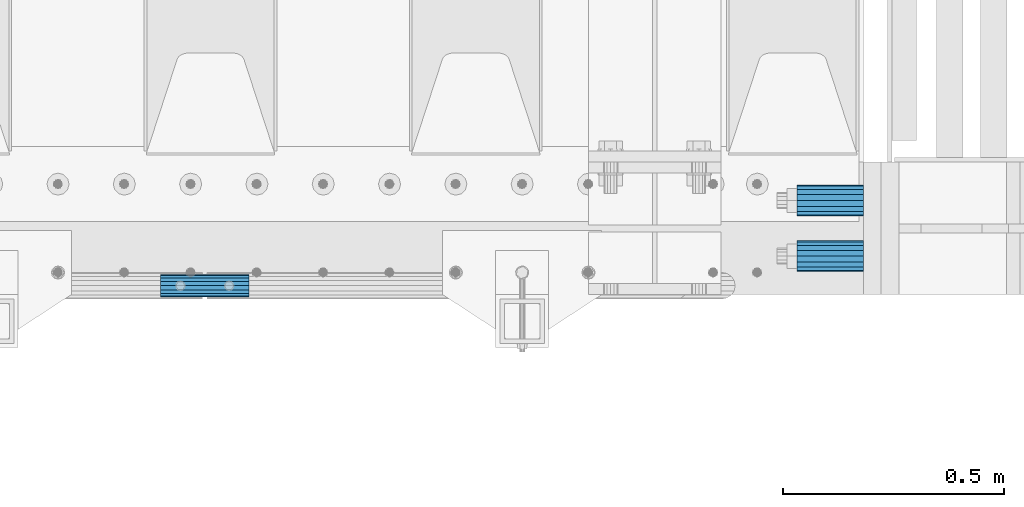
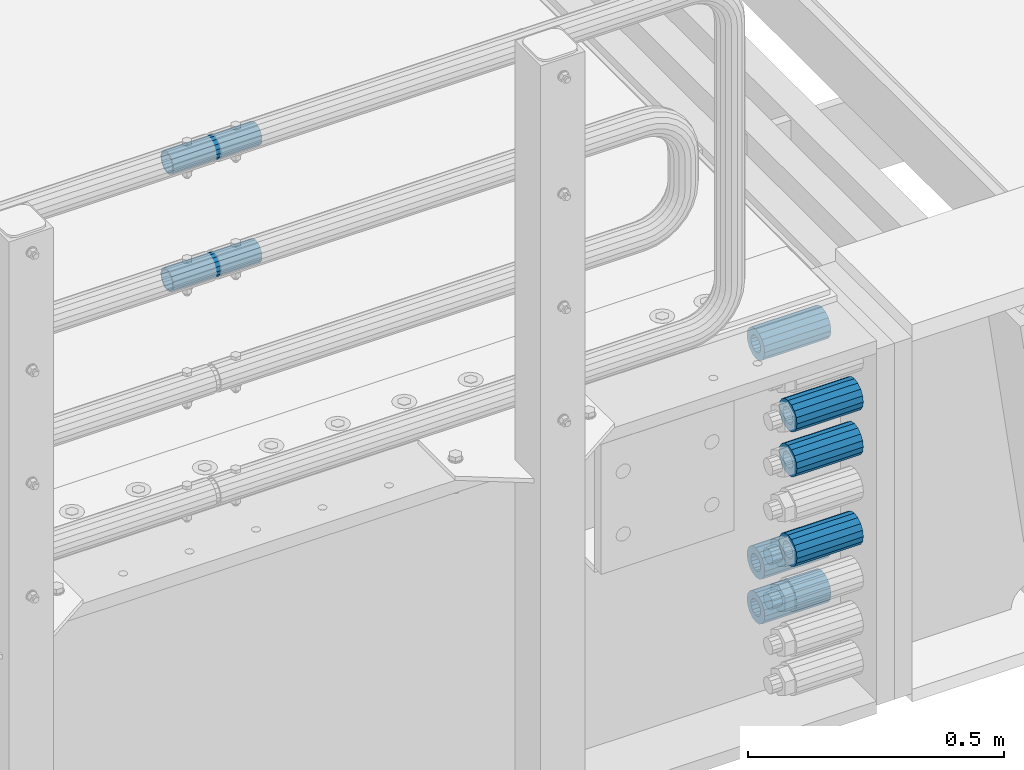
# One storey, part 137 of 240: 8 beams.
"""IFC2X3 building model written with IfcOpenShell, lengths in millimetres."""

from ifc_helpers import new_model, si_unit, frame, origin_with_axes, place, context, subcontext, project, spatial, faceted_brep, material, type_object, element, save


model = new_model("IFC2X3")

# Units and contexts
model_context = context("Model", 3, precision=1e-05, world=origin_with_axes())
body_context = subcontext(model_context, "Body", "Model", "MODEL_VIEW")
ifc_project = project(units=[si_unit("LENGTHUNIT", "METRE", prefix="MILLI"), si_unit("AREAUNIT", "SQUARE_METRE"), si_unit("VOLUMEUNIT", "CUBIC_METRE"), si_unit("MASSUNIT", "GRAM", prefix="KILO"), si_unit("TIMEUNIT", "SECOND"), si_unit("PLANEANGLEUNIT", "RADIAN"), si_unit("SOLIDANGLEUNIT", "STERADIAN"), si_unit("THERMODYNAMICTEMPERATUREUNIT", "DEGREE_CELSIUS"), si_unit("LUMINOUSINTENSITYUNIT", "LUMEN")], contexts=[model_context])

# Site, building, storey
site_placement = place(None, origin_with_axes())
site = spatial("IfcSite", under=ifc_project, at=site_placement, CompositionType="ELEMENT")
building_placement = place(site_placement, origin_with_axes())
building = spatial("IfcBuilding", under=site, at=building_placement, Name="Standard", CompositionType="ELEMENT")
storey_placement = place(building_placement, origin_with_axes())
storey = spatial("IfcBuildingStorey", under=building, at=storey_placement, Name="Undefined", CompositionType="ELEMENT", Elevation=0.0)

# Beams
ifc_material = material()
beam_type_1 = type_object("IfcBeamType", PredefinedType="NOTDEFINED")
beam_1_placement = place(storey_placement, frame((56327.0, 23937.0, -285.0), z_axis=(0.0, 0.0, 1.0), x_axis=(1.0, 0.0, 0.0)))
element("IfcBeam", 1, at=beam_1_placement, inside=storey, type_object=beam_type_1, material=ifc_material, context=body_context, shape_type="Brep", body=[
    faceted_brep([(-1.31236447487026e-07, -18.9999999995492, -6.26459950581193e-09), (0.0, -17.5537111177146, 7.27098521493673), (150.0, -17.5537111177146, 7.27098521493673), (150.0, -19.0, 0.0), (0.0, -13.4350288425449, 13.4350288425444), (150.0, -13.4350288425449, 13.4350288425444), (0.0, -7.27098521493826, 17.5537111177144), (150.0, -7.27098521493826, 17.5537111177144), (-6.35918695479631e-09, 4.50199877377599e-10, 18.9999999937281), (150.0, 0.0, 19.0), (0.0, 7.27098521493826, 17.5537111177144), (150.0, 7.27098521493826, 17.5537111177144), (0.0, 13.4350288425449, 13.4350288425444), (150.0, 13.4350288425449, 13.4350288425444), (0.0, 17.5537111177146, 7.27098521493673), (150.0, 17.5537111177146, 7.27098521493673), (1.33248249767348e-07, 19.0000000004507, -6.26459950581193e-09), (150.0, 19.0, 0.0), (0.0, 17.5537111177146, -7.27098521493673), (150.0, 17.5537111177146, -7.27098521493673), (0.0, 13.4350288425449, -13.4350288425444), (150.0, 13.4350288425449, -13.4350288425444), (0.0, 7.27098521493826, -17.5537111177144), (150.0, 7.27098521493826, -17.5537111177144), (8.37098923511803e-09, 4.50313564215321e-10, -19.0000000062646), (150.0, 0.0, -19.0), (0.0, -7.27098521493826, -17.5537111177144), (150.0, -7.27098521493826, -17.5537111177144), (0.0, -13.4350288425449, -13.4350288425444), (150.0, -13.4350288425449, -13.4350288425444), (0.0, -17.5537111177146, -7.27098521493673), (150.0, -17.5537111177146, -7.27098521493673), (0.0, -35.0, 0.0), (7.27595761418343e-12, -32.335783637895, -13.3939201327739), (150.0, -32.3357836378964, -13.3939201327782), (150.0, -35.0, 0.0), (0.0, -24.7487373415292, -24.7487373415279), (150.0, -24.7487373415279, -24.7487373415292), (7.27595761418343e-12, -13.3939201327781, -32.3357836378891), (150.0, -13.3939201327776, -32.335783637895), (7.27595761418343e-12, 0.0, -35.0), (150.0, 0.0, -35.0), (7.27595761418343e-12, 13.3939201327782, -32.3357836378891), (150.0, 13.3939201327776, -32.335783637895), (0.0, 24.7487373415292, -24.7487373415279), (150.0, 24.7487373415279, -24.7487373415291), (7.27595761418343e-12, 32.335783637895, -13.3939201327739), (150.0, 32.3357836378964, -13.3939201327781), (0.0, 35.0, 0.0), (150.0, 35.0, 0.0), (0.0, 32.335783637895, 13.3939201327812), (150.0, 32.3357836378964, 13.3939201327781), (0.0, 24.7487373415292, 24.7487373415279), (150.0, 24.7487373415279, 24.7487373415292), (0.0, 13.3939201327781, 32.3357836378964), (150.0, 13.3939201327776, 32.335783637895), (0.0, 0.0, 35.0), (150.0, 0.0, 35.0), (0.0, -13.3939201327781, 32.3357836378964), (150.0, -13.3939201327776, 32.335783637895), (0.0, -24.7487373415292, 24.7487373415279), (150.0, -24.7487373415279, 24.7487373415292), (0.0, -32.335783637895, 13.3939201327812), (150.0, -32.3357836378964, 13.3939201327781)], [[[0, 1, 2, 3]], [[1, 4, 5, 2]], [[4, 6, 7, 5]], [[6, 8, 9, 7]], [[8, 10, 11, 9]], [[10, 12, 13, 11]], [[12, 14, 15, 13]], [[14, 16, 17, 15]], [[16, 18, 19, 17]], [[18, 20, 21, 19]], [[20, 22, 23, 21]], [[22, 24, 25, 23]], [[24, 26, 27, 25]], [[26, 28, 29, 27]], [[28, 30, 31, 29]], [[30, 0, 3, 31]], [[32, 33, 34, 35]], [[33, 36, 37, 34]], [[36, 38, 39, 37]], [[38, 40, 41, 39]], [[40, 42, 43, 41]], [[42, 44, 45, 43]], [[44, 46, 47, 45]], [[46, 48, 49, 47]], [[48, 50, 51, 49]], [[50, 52, 53, 51]], [[52, 54, 55, 53]], [[54, 56, 57, 55]], [[56, 58, 59, 57]], [[58, 60, 61, 59]], [[60, 62, 63, 61]], [[62, 32, 35, 63]], [[37, 39, 41, 43, 45, 47, 49, 51, 53, 55, 57, 59, 61, 63, 35, 34], [5, 7, 9, 11, 13, 15, 17, 19, 21, 23, 25, 27, 29, 31, 3, 2]], [[62, 60, 58, 56, 54, 52, 50, 48, 46, 44, 42, 40, 38, 36, 33, 32], [30, 28, 26, 24, 22, 20, 18, 16, 14, 12, 10, 8, 6, 4, 1, 0]]]),
])
beam_2_placement = place(storey_placement, frame((56327.0, 24063.0, -606.0), z_axis=(0.0, 0.0, 1.0), x_axis=(1.0, 0.0, 0.0)))
element("IfcBeam", 2, at=beam_2_placement, inside=storey, type_object=beam_type_1, material=ifc_material, context=body_context, shape_type="Brep", body=[
    faceted_brep([(-1.31236447487026e-07, -18.9999999995492, -6.26459950581193e-09), (0.0, -17.5537111177146, 7.27098521493673), (150.0, -17.5537111177146, 7.27098521493673), (150.0, -19.0, 0.0), (0.0, -13.4350288425449, 13.4350288425444), (150.0, -13.4350288425449, 13.4350288425444), (0.0, -7.27098521493826, 17.5537111177144), (150.0, -7.27098521493826, 17.5537111177144), (-6.35918695479631e-09, 4.50199877377599e-10, 18.9999999937281), (150.0, 0.0, 19.0), (0.0, 7.27098521493826, 17.5537111177144), (150.0, 7.27098521493826, 17.5537111177144), (0.0, 13.4350288425449, 13.4350288425444), (150.0, 13.4350288425449, 13.4350288425444), (0.0, 17.5537111177146, 7.27098521493673), (150.0, 17.5537111177146, 7.27098521493673), (1.33248249767348e-07, 19.0000000004507, -6.26459950581193e-09), (150.0, 19.0, 0.0), (0.0, 17.5537111177146, -7.27098521493673), (150.0, 17.5537111177146, -7.27098521493673), (0.0, 13.4350288425449, -13.4350288425444), (150.0, 13.4350288425449, -13.4350288425444), (0.0, 7.27098521493826, -17.5537111177144), (150.0, 7.27098521493826, -17.5537111177144), (8.37098923511803e-09, 4.50313564215321e-10, -19.0000000062646), (150.0, 0.0, -19.0), (0.0, -7.27098521493826, -17.5537111177144), (150.0, -7.27098521493826, -17.5537111177144), (0.0, -13.4350288425449, -13.4350288425444), (150.0, -13.4350288425449, -13.4350288425444), (0.0, -17.5537111177146, -7.27098521493673), (150.0, -17.5537111177146, -7.27098521493673), (0.0, -35.0, 0.0), (7.27595761418343e-12, -32.335783637895, -13.3939201327739), (150.0, -32.3357836378964, -13.3939201327782), (150.0, -35.0, 0.0), (0.0, -24.7487373415292, -24.7487373415279), (150.0, -24.7487373415279, -24.7487373415292), (7.27595761418343e-12, -13.3939201327781, -32.3357836378891), (150.0, -13.3939201327776, -32.335783637895), (7.27595761418343e-12, 0.0, -35.0), (150.0, 0.0, -35.0), (7.27595761418343e-12, 13.3939201327782, -32.3357836378891), (150.0, 13.3939201327776, -32.335783637895), (0.0, 24.7487373415292, -24.7487373415279), (150.0, 24.7487373415279, -24.7487373415291), (7.27595761418343e-12, 32.335783637895, -13.3939201327739), (150.0, 32.3357836378964, -13.3939201327781), (0.0, 35.0, 0.0), (150.0, 35.0, 0.0), (0.0, 32.335783637895, 13.3939201327812), (150.0, 32.3357836378964, 13.3939201327781), (0.0, 24.7487373415292, 24.7487373415279), (150.0, 24.7487373415279, 24.7487373415292), (0.0, 13.3939201327781, 32.3357836378964), (150.0, 13.3939201327776, 32.335783637895), (0.0, 0.0, 35.0), (150.0, 0.0, 35.0), (0.0, -13.3939201327781, 32.3357836378964), (150.0, -13.3939201327776, 32.335783637895), (0.0, -24.7487373415292, 24.7487373415279), (150.0, -24.7487373415279, 24.7487373415292), (0.0, -32.335783637895, 13.3939201327812), (150.0, -32.3357836378964, 13.3939201327781)], [[[0, 1, 2, 3]], [[1, 4, 5, 2]], [[4, 6, 7, 5]], [[6, 8, 9, 7]], [[8, 10, 11, 9]], [[10, 12, 13, 11]], [[12, 14, 15, 13]], [[14, 16, 17, 15]], [[16, 18, 19, 17]], [[18, 20, 21, 19]], [[20, 22, 23, 21]], [[22, 24, 25, 23]], [[24, 26, 27, 25]], [[26, 28, 29, 27]], [[28, 30, 31, 29]], [[30, 0, 3, 31]], [[32, 33, 34, 35]], [[33, 36, 37, 34]], [[36, 38, 39, 37]], [[38, 40, 41, 39]], [[40, 42, 43, 41]], [[42, 44, 45, 43]], [[44, 46, 47, 45]], [[46, 48, 49, 47]], [[48, 50, 51, 49]], [[50, 52, 53, 51]], [[52, 54, 55, 53]], [[54, 56, 57, 55]], [[56, 58, 59, 57]], [[58, 60, 61, 59]], [[60, 62, 63, 61]], [[62, 32, 35, 63]], [[37, 39, 41, 43, 45, 47, 49, 51, 53, 55, 57, 59, 61, 63, 35, 34], [5, 7, 9, 11, 13, 15, 17, 19, 21, 23, 25, 27, 29, 31, 3, 2]], [[62, 60, 58, 56, 54, 52, 50, 48, 46, 44, 42, 40, 38, 36, 33, 32], [30, 28, 26, 24, 22, 20, 18, 16, 14, 12, 10, 8, 6, 4, 1, 0]]]),
])
beam_3_placement = place(storey_placement, frame((56327.0, 24063.0, -713.0), z_axis=(0.0, 0.0, 1.0), x_axis=(1.0, 0.0, 0.0)))
element("IfcBeam", 3, at=beam_3_placement, inside=storey, type_object=beam_type_1, material=ifc_material, context=body_context, shape_type="Brep", body=[
    faceted_brep([(-1.31236447487026e-07, -18.9999999995492, -6.26459950581193e-09), (0.0, -17.5537111177146, 7.27098521493673), (150.0, -17.5537111177146, 7.27098521493673), (150.0, -19.0, 0.0), (0.0, -13.4350288425449, 13.4350288425444), (150.0, -13.4350288425449, 13.4350288425444), (0.0, -7.27098521493826, 17.5537111177144), (150.0, -7.27098521493826, 17.5537111177144), (-6.35918695479631e-09, 4.50199877377599e-10, 18.9999999937281), (150.0, 0.0, 19.0), (0.0, 7.27098521493826, 17.5537111177144), (150.0, 7.27098521493826, 17.5537111177144), (0.0, 13.4350288425449, 13.4350288425444), (150.0, 13.4350288425449, 13.4350288425444), (0.0, 17.5537111177146, 7.27098521493673), (150.0, 17.5537111177146, 7.27098521493673), (1.33248249767348e-07, 19.0000000004507, -6.26459950581193e-09), (150.0, 19.0, 0.0), (0.0, 17.5537111177146, -7.27098521493673), (150.0, 17.5537111177146, -7.27098521493673), (0.0, 13.4350288425449, -13.4350288425444), (150.0, 13.4350288425449, -13.4350288425444), (0.0, 7.27098521493826, -17.5537111177144), (150.0, 7.27098521493826, -17.5537111177144), (8.37098923511803e-09, 4.50313564215321e-10, -19.0000000062646), (150.0, 0.0, -19.0), (0.0, -7.27098521493826, -17.5537111177144), (150.0, -7.27098521493826, -17.5537111177144), (0.0, -13.4350288425449, -13.4350288425444), (150.0, -13.4350288425449, -13.4350288425444), (0.0, -17.5537111177146, -7.27098521493673), (150.0, -17.5537111177146, -7.27098521493673), (0.0, -35.0, 0.0), (7.27595761418343e-12, -32.335783637895, -13.3939201327739), (150.0, -32.3357836378964, -13.3939201327782), (150.0, -35.0, 0.0), (0.0, -24.7487373415292, -24.7487373415279), (150.0, -24.7487373415279, -24.7487373415292), (7.27595761418343e-12, -13.3939201327781, -32.3357836378891), (150.0, -13.3939201327776, -32.335783637895), (7.27595761418343e-12, 0.0, -35.0), (150.0, 0.0, -35.0), (7.27595761418343e-12, 13.3939201327782, -32.3357836378891), (150.0, 13.3939201327776, -32.335783637895), (0.0, 24.7487373415292, -24.7487373415279), (150.0, 24.7487373415279, -24.7487373415291), (7.27595761418343e-12, 32.335783637895, -13.3939201327739), (150.0, 32.3357836378964, -13.3939201327781), (0.0, 35.0, 0.0), (150.0, 35.0, 0.0), (0.0, 32.335783637895, 13.3939201327812), (150.0, 32.3357836378964, 13.3939201327781), (0.0, 24.7487373415292, 24.7487373415279), (150.0, 24.7487373415279, 24.7487373415292), (0.0, 13.3939201327781, 32.3357836378964), (150.0, 13.3939201327776, 32.335783637895), (0.0, 0.0, 35.0), (150.0, 0.0, 35.0), (0.0, -13.3939201327781, 32.3357836378964), (150.0, -13.3939201327776, 32.335783637895), (0.0, -24.7487373415292, 24.7487373415279), (150.0, -24.7487373415279, 24.7487373415292), (0.0, -32.335783637895, 13.3939201327812), (150.0, -32.3357836378964, 13.3939201327781)], [[[0, 1, 2, 3]], [[1, 4, 5, 2]], [[4, 6, 7, 5]], [[6, 8, 9, 7]], [[8, 10, 11, 9]], [[10, 12, 13, 11]], [[12, 14, 15, 13]], [[14, 16, 17, 15]], [[16, 18, 19, 17]], [[18, 20, 21, 19]], [[20, 22, 23, 21]], [[22, 24, 25, 23]], [[24, 26, 27, 25]], [[26, 28, 29, 27]], [[28, 30, 31, 29]], [[30, 0, 3, 31]], [[32, 33, 34, 35]], [[33, 36, 37, 34]], [[36, 38, 39, 37]], [[38, 40, 41, 39]], [[40, 42, 43, 41]], [[42, 44, 45, 43]], [[44, 46, 47, 45]], [[46, 48, 49, 47]], [[48, 50, 51, 49]], [[50, 52, 53, 51]], [[52, 54, 55, 53]], [[54, 56, 57, 55]], [[56, 58, 59, 57]], [[58, 60, 61, 59]], [[60, 62, 63, 61]], [[62, 32, 35, 63]], [[37, 39, 41, 43, 45, 47, 49, 51, 53, 55, 57, 59, 61, 63, 35, 34], [5, 7, 9, 11, 13, 15, 17, 19, 21, 23, 25, 27, 29, 31, 3, 2]], [[62, 60, 58, 56, 54, 52, 50, 48, 46, 44, 42, 40, 38, 36, 33, 32], [30, 28, 26, 24, 22, 20, 18, 16, 14, 12, 10, 8, 6, 4, 1, 0]]]),
])
beam_4_placement = place(storey_placement, frame((56327.0, 23937.0, -499.0), z_axis=(0.0, 0.0, 1.0), x_axis=(1.0, 0.0, 0.0)))
element("IfcBeam", 4, at=beam_4_placement, inside=storey, type_object=beam_type_1, material=ifc_material, context=body_context, shape_type="Brep", body=[
    faceted_brep([(-1.31236447487026e-07, -18.9999999995492, -6.26459950581193e-09), (0.0, -17.5537111177146, 7.27098521493673), (150.0, -17.5537111177146, 7.27098521493673), (150.0, -19.0, 0.0), (0.0, -13.4350288425449, 13.4350288425444), (150.0, -13.4350288425449, 13.4350288425444), (0.0, -7.27098521493826, 17.5537111177144), (150.0, -7.27098521493826, 17.5537111177144), (-6.35918695479631e-09, 4.50199877377599e-10, 18.9999999937281), (150.0, 0.0, 19.0), (0.0, 7.27098521493826, 17.5537111177144), (150.0, 7.27098521493826, 17.5537111177144), (0.0, 13.4350288425449, 13.4350288425444), (150.0, 13.4350288425449, 13.4350288425444), (0.0, 17.5537111177146, 7.27098521493673), (150.0, 17.5537111177146, 7.27098521493673), (1.33248249767348e-07, 19.0000000004507, -6.26459950581193e-09), (150.0, 19.0, 0.0), (0.0, 17.5537111177146, -7.27098521493673), (150.0, 17.5537111177146, -7.27098521493673), (0.0, 13.4350288425449, -13.4350288425444), (150.0, 13.4350288425449, -13.4350288425444), (0.0, 7.27098521493826, -17.5537111177144), (150.0, 7.27098521493826, -17.5537111177144), (8.37098923511803e-09, 4.50313564215321e-10, -19.0000000062646), (150.0, 0.0, -19.0), (0.0, -7.27098521493826, -17.5537111177144), (150.0, -7.27098521493826, -17.5537111177144), (0.0, -13.4350288425449, -13.4350288425444), (150.0, -13.4350288425449, -13.4350288425444), (0.0, -17.5537111177146, -7.27098521493673), (150.0, -17.5537111177146, -7.27098521493673), (0.0, -35.0, 0.0), (7.27595761418343e-12, -32.335783637895, -13.3939201327739), (150.0, -32.3357836378964, -13.3939201327782), (150.0, -35.0, 0.0), (0.0, -24.7487373415292, -24.7487373415279), (150.0, -24.7487373415279, -24.7487373415292), (7.27595761418343e-12, -13.3939201327781, -32.3357836378891), (150.0, -13.3939201327776, -32.335783637895), (7.27595761418343e-12, 0.0, -35.0), (150.0, 0.0, -35.0), (7.27595761418343e-12, 13.3939201327782, -32.3357836378891), (150.0, 13.3939201327776, -32.335783637895), (0.0, 24.7487373415292, -24.7487373415279), (150.0, 24.7487373415279, -24.7487373415291), (7.27595761418343e-12, 32.335783637895, -13.3939201327739), (150.0, 32.3357836378964, -13.3939201327781), (0.0, 35.0, 0.0), (150.0, 35.0, 0.0), (0.0, 32.335783637895, 13.3939201327812), (150.0, 32.3357836378964, 13.3939201327781), (0.0, 24.7487373415292, 24.7487373415279), (150.0, 24.7487373415279, 24.7487373415292), (0.0, 13.3939201327781, 32.3357836378964), (150.0, 13.3939201327776, 32.335783637895), (0.0, 0.0, 35.0), (150.0, 0.0, 35.0), (0.0, -13.3939201327781, 32.3357836378964), (150.0, -13.3939201327776, 32.335783637895), (0.0, -24.7487373415292, 24.7487373415279), (150.0, -24.7487373415279, 24.7487373415292), (0.0, -32.335783637895, 13.3939201327812), (150.0, -32.3357836378964, 13.3939201327781)], [[[0, 1, 2, 3]], [[1, 4, 5, 2]], [[4, 6, 7, 5]], [[6, 8, 9, 7]], [[8, 10, 11, 9]], [[10, 12, 13, 11]], [[12, 14, 15, 13]], [[14, 16, 17, 15]], [[16, 18, 19, 17]], [[18, 20, 21, 19]], [[20, 22, 23, 21]], [[22, 24, 25, 23]], [[24, 26, 27, 25]], [[26, 28, 29, 27]], [[28, 30, 31, 29]], [[30, 0, 3, 31]], [[32, 33, 34, 35]], [[33, 36, 37, 34]], [[36, 38, 39, 37]], [[38, 40, 41, 39]], [[40, 42, 43, 41]], [[42, 44, 45, 43]], [[44, 46, 47, 45]], [[46, 48, 49, 47]], [[48, 50, 51, 49]], [[50, 52, 53, 51]], [[52, 54, 55, 53]], [[54, 56, 57, 55]], [[56, 58, 59, 57]], [[58, 60, 61, 59]], [[60, 62, 63, 61]], [[62, 32, 35, 63]], [[37, 39, 41, 43, 45, 47, 49, 51, 53, 55, 57, 59, 61, 63, 35, 34], [5, 7, 9, 11, 13, 15, 17, 19, 21, 23, 25, 27, 29, 31, 3, 2]], [[62, 60, 58, 56, 54, 52, 50, 48, 46, 44, 42, 40, 38, 36, 33, 32], [30, 28, 26, 24, 22, 20, 18, 16, 14, 12, 10, 8, 6, 4, 1, 0]]]),
])
beam_5_placement = place(storey_placement, frame((56327.0, 24063.0, -84.0000000000001), z_axis=(0.0, 0.0, 1.0), x_axis=(1.0, 0.0, 0.0)))
element("IfcBeam", 5, at=beam_5_placement, inside=storey, type_object=beam_type_1, material=ifc_material, context=body_context, shape_type="Brep", body=[
    faceted_brep([(-1.31236447487026e-07, -18.9999999995492, -6.26459950581193e-09), (0.0, -17.5537111177146, 7.27098521493673), (150.0, -17.5537111177146, 7.27098521493673), (150.0, -19.0, 0.0), (0.0, -13.4350288425449, 13.4350288425444), (150.0, -13.4350288425449, 13.4350288425444), (0.0, -7.27098521493826, 17.5537111177144), (150.0, -7.27098521493826, 17.5537111177144), (-6.35918695479631e-09, 4.50199877377599e-10, 18.9999999937281), (150.0, 0.0, 19.0), (0.0, 7.27098521493826, 17.5537111177144), (150.0, 7.27098521493826, 17.5537111177144), (0.0, 13.4350288425449, 13.4350288425444), (150.0, 13.4350288425449, 13.4350288425444), (0.0, 17.5537111177146, 7.27098521493673), (150.0, 17.5537111177146, 7.27098521493673), (1.33248249767348e-07, 19.0000000004507, -6.26459950581193e-09), (150.0, 19.0, 0.0), (0.0, 17.5537111177146, -7.27098521493673), (150.0, 17.5537111177146, -7.27098521493673), (0.0, 13.4350288425449, -13.4350288425444), (150.0, 13.4350288425449, -13.4350288425444), (0.0, 7.27098521493826, -17.5537111177144), (150.0, 7.27098521493826, -17.5537111177144), (8.37098923511803e-09, 4.50313564215321e-10, -19.0000000062646), (150.0, 0.0, -19.0), (0.0, -7.27098521493826, -17.5537111177144), (150.0, -7.27098521493826, -17.5537111177144), (0.0, -13.4350288425449, -13.4350288425444), (150.0, -13.4350288425449, -13.4350288425444), (0.0, -17.5537111177146, -7.27098521493673), (150.0, -17.5537111177146, -7.27098521493673), (0.0, -35.0, 0.0), (7.27595761418343e-12, -32.335783637895, -13.3939201327739), (150.0, -32.3357836378964, -13.3939201327782), (150.0, -35.0, 0.0), (0.0, -24.7487373415292, -24.7487373415279), (150.0, -24.7487373415279, -24.7487373415292), (7.27595761418343e-12, -13.3939201327781, -32.3357836378891), (150.0, -13.3939201327776, -32.335783637895), (7.27595761418343e-12, 0.0, -35.0), (150.0, 0.0, -35.0), (7.27595761418343e-12, 13.3939201327782, -32.3357836378891), (150.0, 13.3939201327776, -32.335783637895), (0.0, 24.7487373415292, -24.7487373415279), (150.0, 24.7487373415279, -24.7487373415291), (7.27595761418343e-12, 32.335783637895, -13.3939201327739), (150.0, 32.3357836378964, -13.3939201327781), (0.0, 35.0, 0.0), (150.0, 35.0, 0.0), (0.0, 32.335783637895, 13.3939201327812), (150.0, 32.3357836378964, 13.3939201327781), (0.0, 24.7487373415292, 24.7487373415279), (150.0, 24.7487373415279, 24.7487373415292), (0.0, 13.3939201327781, 32.3357836378964), (150.0, 13.3939201327776, 32.335783637895), (0.0, 0.0, 35.0), (150.0, 0.0, 35.0), (0.0, -13.3939201327781, 32.3357836378964), (150.0, -13.3939201327776, 32.335783637895), (0.0, -24.7487373415292, 24.7487373415279), (150.0, -24.7487373415279, 24.7487373415292), (0.0, -32.335783637895, 13.3939201327812), (150.0, -32.3357836378964, 13.3939201327781)], [[[0, 1, 2, 3]], [[1, 4, 5, 2]], [[4, 6, 7, 5]], [[6, 8, 9, 7]], [[8, 10, 11, 9]], [[10, 12, 13, 11]], [[12, 14, 15, 13]], [[14, 16, 17, 15]], [[16, 18, 19, 17]], [[18, 20, 21, 19]], [[20, 22, 23, 21]], [[22, 24, 25, 23]], [[24, 26, 27, 25]], [[26, 28, 29, 27]], [[28, 30, 31, 29]], [[30, 0, 3, 31]], [[32, 33, 34, 35]], [[33, 36, 37, 34]], [[36, 38, 39, 37]], [[38, 40, 41, 39]], [[40, 42, 43, 41]], [[42, 44, 45, 43]], [[44, 46, 47, 45]], [[46, 48, 49, 47]], [[48, 50, 51, 49]], [[50, 52, 53, 51]], [[52, 54, 55, 53]], [[54, 56, 57, 55]], [[56, 58, 59, 57]], [[58, 60, 61, 59]], [[60, 62, 63, 61]], [[62, 32, 35, 63]], [[37, 39, 41, 43, 45, 47, 49, 51, 53, 55, 57, 59, 61, 63, 35, 34], [5, 7, 9, 11, 13, 15, 17, 19, 21, 23, 25, 27, 29, 31, 3, 2]], [[62, 60, 58, 56, 54, 52, 50, 48, 46, 44, 42, 40, 38, 36, 33, 32], [30, 28, 26, 24, 22, 20, 18, 16, 14, 12, 10, 8, 6, 4, 1, 0]]]),
])
beam_6_placement = place(storey_placement, frame((56327.0, 23937.0, -178.0), z_axis=(0.0, 0.0, 1.0), x_axis=(1.0, 0.0, 0.0)))
element("IfcBeam", 6, at=beam_6_placement, inside=storey, type_object=beam_type_1, material=ifc_material, context=body_context, shape_type="Brep", body=[
    faceted_brep([(-1.31236447487026e-07, -18.9999999995492, -6.26459950581193e-09), (0.0, -17.5537111177146, 7.27098521493673), (150.0, -17.5537111177146, 7.27098521493673), (150.0, -19.0, 0.0), (0.0, -13.4350288425449, 13.4350288425444), (150.0, -13.4350288425449, 13.4350288425444), (0.0, -7.27098521493826, 17.5537111177144), (150.0, -7.27098521493826, 17.5537111177144), (-6.35918695479631e-09, 4.50199877377599e-10, 18.9999999937281), (150.0, 0.0, 19.0), (0.0, 7.27098521493826, 17.5537111177144), (150.0, 7.27098521493826, 17.5537111177144), (0.0, 13.4350288425449, 13.4350288425444), (150.0, 13.4350288425449, 13.4350288425444), (0.0, 17.5537111177146, 7.27098521493673), (150.0, 17.5537111177146, 7.27098521493673), (1.33248249767348e-07, 19.0000000004507, -6.26459950581193e-09), (150.0, 19.0, 0.0), (0.0, 17.5537111177146, -7.27098521493673), (150.0, 17.5537111177146, -7.27098521493673), (0.0, 13.4350288425449, -13.4350288425444), (150.0, 13.4350288425449, -13.4350288425444), (0.0, 7.27098521493826, -17.5537111177144), (150.0, 7.27098521493826, -17.5537111177144), (8.37098923511803e-09, 4.50313564215321e-10, -19.0000000062646), (150.0, 0.0, -19.0), (0.0, -7.27098521493826, -17.5537111177144), (150.0, -7.27098521493826, -17.5537111177144), (0.0, -13.4350288425449, -13.4350288425444), (150.0, -13.4350288425449, -13.4350288425444), (0.0, -17.5537111177146, -7.27098521493673), (150.0, -17.5537111177146, -7.27098521493673), (0.0, -35.0, 0.0), (7.27595761418343e-12, -32.335783637895, -13.3939201327739), (150.0, -32.3357836378964, -13.3939201327782), (150.0, -35.0, 0.0), (0.0, -24.7487373415292, -24.7487373415279), (150.0, -24.7487373415279, -24.7487373415292), (7.27595761418343e-12, -13.3939201327781, -32.3357836378891), (150.0, -13.3939201327776, -32.335783637895), (7.27595761418343e-12, 0.0, -35.0), (150.0, 0.0, -35.0), (7.27595761418343e-12, 13.3939201327782, -32.3357836378891), (150.0, 13.3939201327776, -32.335783637895), (0.0, 24.7487373415292, -24.7487373415279), (150.0, 24.7487373415279, -24.7487373415291), (7.27595761418343e-12, 32.335783637895, -13.3939201327739), (150.0, 32.3357836378964, -13.3939201327781), (0.0, 35.0, 0.0), (150.0, 35.0, 0.0), (0.0, 32.335783637895, 13.3939201327812), (150.0, 32.3357836378964, 13.3939201327781), (0.0, 24.7487373415292, 24.7487373415279), (150.0, 24.7487373415279, 24.7487373415292), (0.0, 13.3939201327781, 32.3357836378964), (150.0, 13.3939201327776, 32.335783637895), (0.0, 0.0, 35.0), (150.0, 0.0, 35.0), (0.0, -13.3939201327781, 32.3357836378964), (150.0, -13.3939201327776, 32.335783637895), (0.0, -24.7487373415292, 24.7487373415279), (150.0, -24.7487373415279, 24.7487373415292), (0.0, -32.335783637895, 13.3939201327812), (150.0, -32.3357836378964, 13.3939201327781)], [[[0, 1, 2, 3]], [[1, 4, 5, 2]], [[4, 6, 7, 5]], [[6, 8, 9, 7]], [[8, 10, 11, 9]], [[10, 12, 13, 11]], [[12, 14, 15, 13]], [[14, 16, 17, 15]], [[16, 18, 19, 17]], [[18, 20, 21, 19]], [[20, 22, 23, 21]], [[22, 24, 25, 23]], [[24, 26, 27, 25]], [[26, 28, 29, 27]], [[28, 30, 31, 29]], [[30, 0, 3, 31]], [[32, 33, 34, 35]], [[33, 36, 37, 34]], [[36, 38, 39, 37]], [[38, 40, 41, 39]], [[40, 42, 43, 41]], [[42, 44, 45, 43]], [[44, 46, 47, 45]], [[46, 48, 49, 47]], [[48, 50, 51, 49]], [[50, 52, 53, 51]], [[52, 54, 55, 53]], [[54, 56, 57, 55]], [[56, 58, 59, 57]], [[58, 60, 61, 59]], [[60, 62, 63, 61]], [[62, 32, 35, 63]], [[37, 39, 41, 43, 45, 47, 49, 51, 53, 55, 57, 59, 61, 63, 35, 34], [5, 7, 9, 11, 13, 15, 17, 19, 21, 23, 25, 27, 29, 31, 3, 2]], [[62, 60, 58, 56, 54, 52, 50, 48, 46, 44, 42, 40, 38, 36, 33, 32], [30, 28, 26, 24, 22, 20, 18, 16, 14, 12, 10, 8, 6, 4, 1, 0]]]),
])
beam_type_2 = type_object("IfcBeamType", PredefinedType="NOTDEFINED")
beam_7_placement = place(storey_placement, frame((54886.9975029999, 23870.1500000004, 689.849999999747), z_axis=(0.0, 0.0, 1.0), x_axis=(1.0, 0.0, 0.0)))
element("IfcBeam", 7, at=beam_7_placement, inside=storey, type_object=beam_type_2, material=ifc_material, context=body_context, shape_type="Brep", body=[
    faceted_brep([(0.0, -21.9000000000015, 0.0), (0.0, -20.232961761998, 8.38076716879547), (200.0, -20.232961761998, 8.38076716879547), (200.0, -21.9000000000015, 0.0), (0.0, -15.4856385079838, 15.4856385079854), (200.0, -15.4856385079838, 15.4856385079854), (0.0, -8.38076716879732, 20.2329617619972), (200.0, -8.38076716879732, 20.2329617619972), (0.0, 0.0, 21.9), (200.0, 0.0, 21.9), (0.0, 8.38076716879732, 20.2329617619972), (200.0, 8.38076716879732, 20.2329617619972), (0.0, 15.4856385079838, 15.4856385079854), (200.0, 15.4856385079838, 15.4856385079854), (0.0, 20.232961761998, 8.38076716879547), (200.0, 20.232961761998, 8.38076716879547), (0.0, 21.9000000000015, 0.0), (200.0, 21.9000000000015, 0.0), (0.0, 20.232961761998, -8.38076716879547), (200.0, 20.232961761998, -8.38076716879547), (0.0, 15.4856385079838, -15.4856385079854), (200.0, 15.4856385079838, -15.4856385079854), (0.0, 8.38076716879732, -20.2329617619972), (200.0, 8.38076716879732, -20.2329617619972), (0.0, 0.0, -21.9), (200.0, 0.0, -21.9), (0.0, -8.38076716879732, -20.2329617619972), (200.0, -8.38076716879732, -20.2329617619972), (0.0, -15.4856385079838, -15.4856385079854), (200.0, -15.4856385079838, -15.4856385079854), (0.0, -20.232961761998, -8.38076716879547), (200.0, -20.232961761998, -8.38076716879547), (0.0, -25.5, 0.0), (0.0, -23.5589280790373, -9.7584275253098), (200.0, -23.5589280790373, -9.7584275253098), (200.0, -25.5, 0.0), (0.0, -18.0312229202536, -18.031222920257), (200.0, -18.0312229202536, -18.031222920257), (0.0, -9.75842752531025, -23.5589280790378), (200.0, -9.75842752531025, -23.5589280790378), (0.0, 0.0, -25.5), (200.0, 0.0, -25.5), (0.0, 9.75842752531025, -23.5589280790378), (200.0, 9.75842752531025, -23.5589280790378), (0.0, 18.0312229202536, -18.031222920257), (200.0, 18.0312229202536, -18.031222920257), (0.0, 23.5589280790373, -9.7584275253098), (200.0, 23.5589280790373, -9.7584275253098), (0.0, 25.5, 0.0), (200.0, 25.5, 0.0), (0.0, 23.5589280790373, 9.7584275253098), (200.0, 23.5589280790373, 9.7584275253098), (0.0, 18.0312229202536, 18.031222920257), (200.0, 18.0312229202536, 18.031222920257), (0.0, 9.75842752531025, 23.5589280790378), (200.0, 9.75842752531025, 23.5589280790378), (0.0, 0.0, 25.5), (200.0, 0.0, 25.5), (0.0, -9.75842752531025, 23.5589280790378), (200.0, -9.75842752531025, 23.5589280790378), (0.0, -18.0312229202536, 18.031222920257), (200.0, -18.0312229202536, 18.031222920257), (0.0, -23.5589280790373, 9.7584275253098), (200.0, -23.5589280790373, 9.7584275253098)], [[[0, 1, 2, 3]], [[1, 4, 5, 2]], [[4, 6, 7, 5]], [[6, 8, 9, 7]], [[8, 10, 11, 9]], [[10, 12, 13, 11]], [[12, 14, 15, 13]], [[14, 16, 17, 15]], [[16, 18, 19, 17]], [[18, 20, 21, 19]], [[20, 22, 23, 21]], [[22, 24, 25, 23]], [[24, 26, 27, 25]], [[26, 28, 29, 27]], [[28, 30, 31, 29]], [[30, 0, 3, 31]], [[32, 33, 34, 35]], [[33, 36, 37, 34]], [[36, 38, 39, 37]], [[38, 40, 41, 39]], [[40, 42, 43, 41]], [[42, 44, 45, 43]], [[44, 46, 47, 45]], [[46, 48, 49, 47]], [[48, 50, 51, 49]], [[50, 52, 53, 51]], [[52, 54, 55, 53]], [[54, 56, 57, 55]], [[56, 58, 59, 57]], [[58, 60, 61, 59]], [[60, 62, 63, 61]], [[62, 32, 35, 63]], [[37, 39, 41, 43, 45, 47, 49, 51, 53, 55, 57, 59, 61, 63, 35, 34], [5, 7, 9, 11, 13, 15, 17, 19, 21, 23, 25, 27, 29, 31, 3, 2]], [[62, 60, 58, 56, 54, 52, 50, 48, 46, 44, 42, 40, 38, 36, 33, 32], [30, 28, 26, 24, 22, 20, 18, 16, 14, 12, 10, 8, 6, 4, 1, 0]]]),
])
beam_8_placement = place(storey_placement, frame((54886.9975029999, 23870.1500000005, 969.849999999747), z_axis=(0.0, 0.0, 1.0), x_axis=(1.0, 0.0, 0.0)))
element("IfcBeam", 8, at=beam_8_placement, inside=storey, type_object=beam_type_2, material=ifc_material, context=body_context, shape_type="Brep", body=[
    faceted_brep([(0.0, -21.9000000000015, 0.0), (0.0, -20.232961761998, 8.38076716879547), (200.0, -20.232961761998, 8.38076716879547), (200.0, -21.9000000000015, 0.0), (0.0, -15.4856385079838, 15.4856385079854), (200.0, -15.4856385079838, 15.4856385079854), (0.0, -8.38076716879732, 20.2329617619972), (200.0, -8.38076716879732, 20.2329617619972), (0.0, 0.0, 21.9), (200.0, 0.0, 21.9), (0.0, 8.38076716879732, 20.2329617619972), (200.0, 8.38076716879732, 20.2329617619972), (0.0, 15.4856385079838, 15.4856385079854), (200.0, 15.4856385079838, 15.4856385079854), (0.0, 20.232961761998, 8.38076716879547), (200.0, 20.232961761998, 8.38076716879547), (0.0, 21.9000000000015, 0.0), (200.0, 21.9000000000015, 0.0), (0.0, 20.232961761998, -8.38076716879547), (200.0, 20.232961761998, -8.38076716879547), (0.0, 15.4856385079838, -15.4856385079854), (200.0, 15.4856385079838, -15.4856385079854), (0.0, 8.38076716879732, -20.2329617619972), (200.0, 8.38076716879732, -20.2329617619972), (0.0, 0.0, -21.9), (200.0, 0.0, -21.9), (0.0, -8.38076716879732, -20.2329617619972), (200.0, -8.38076716879732, -20.2329617619972), (0.0, -15.4856385079838, -15.4856385079854), (200.0, -15.4856385079838, -15.4856385079854), (0.0, -20.232961761998, -8.38076716879547), (200.0, -20.232961761998, -8.38076716879547), (0.0, -25.5, 0.0), (0.0, -23.5589280790373, -9.7584275253098), (200.0, -23.5589280790373, -9.7584275253098), (200.0, -25.5, 0.0), (0.0, -18.0312229202536, -18.031222920257), (200.0, -18.0312229202536, -18.031222920257), (0.0, -9.75842752531025, -23.5589280790378), (200.0, -9.75842752531025, -23.5589280790378), (0.0, 0.0, -25.5), (200.0, 0.0, -25.5), (0.0, 9.75842752531025, -23.5589280790378), (200.0, 9.75842752531025, -23.5589280790378), (0.0, 18.0312229202536, -18.031222920257), (200.0, 18.0312229202536, -18.031222920257), (0.0, 23.5589280790373, -9.7584275253098), (200.0, 23.5589280790373, -9.7584275253098), (0.0, 25.5, 0.0), (200.0, 25.5, 0.0), (0.0, 23.5589280790373, 9.7584275253098), (200.0, 23.5589280790373, 9.7584275253098), (0.0, 18.0312229202536, 18.031222920257), (200.0, 18.0312229202536, 18.031222920257), (0.0, 9.75842752531025, 23.5589280790378), (200.0, 9.75842752531025, 23.5589280790378), (0.0, 0.0, 25.5), (200.0, 0.0, 25.5), (0.0, -9.75842752531025, 23.5589280790378), (200.0, -9.75842752531025, 23.5589280790378), (0.0, -18.0312229202536, 18.031222920257), (200.0, -18.0312229202536, 18.031222920257), (0.0, -23.5589280790373, 9.7584275253098), (200.0, -23.5589280790373, 9.7584275253098)], [[[0, 1, 2, 3]], [[1, 4, 5, 2]], [[4, 6, 7, 5]], [[6, 8, 9, 7]], [[8, 10, 11, 9]], [[10, 12, 13, 11]], [[12, 14, 15, 13]], [[14, 16, 17, 15]], [[16, 18, 19, 17]], [[18, 20, 21, 19]], [[20, 22, 23, 21]], [[22, 24, 25, 23]], [[24, 26, 27, 25]], [[26, 28, 29, 27]], [[28, 30, 31, 29]], [[30, 0, 3, 31]], [[32, 33, 34, 35]], [[33, 36, 37, 34]], [[36, 38, 39, 37]], [[38, 40, 41, 39]], [[40, 42, 43, 41]], [[42, 44, 45, 43]], [[44, 46, 47, 45]], [[46, 48, 49, 47]], [[48, 50, 51, 49]], [[50, 52, 53, 51]], [[52, 54, 55, 53]], [[54, 56, 57, 55]], [[56, 58, 59, 57]], [[58, 60, 61, 59]], [[60, 62, 63, 61]], [[62, 32, 35, 63]], [[37, 39, 41, 43, 45, 47, 49, 51, 53, 55, 57, 59, 61, 63, 35, 34], [5, 7, 9, 11, 13, 15, 17, 19, 21, 23, 25, 27, 29, 31, 3, 2]], [[62, 60, 58, 56, 54, 52, 50, 48, 46, 44, 42, 40, 38, 36, 33, 32], [30, 28, 26, 24, 22, 20, 18, 16, 14, 12, 10, 8, 6, 4, 1, 0]]]),
])

save(model, "model.ifc")
